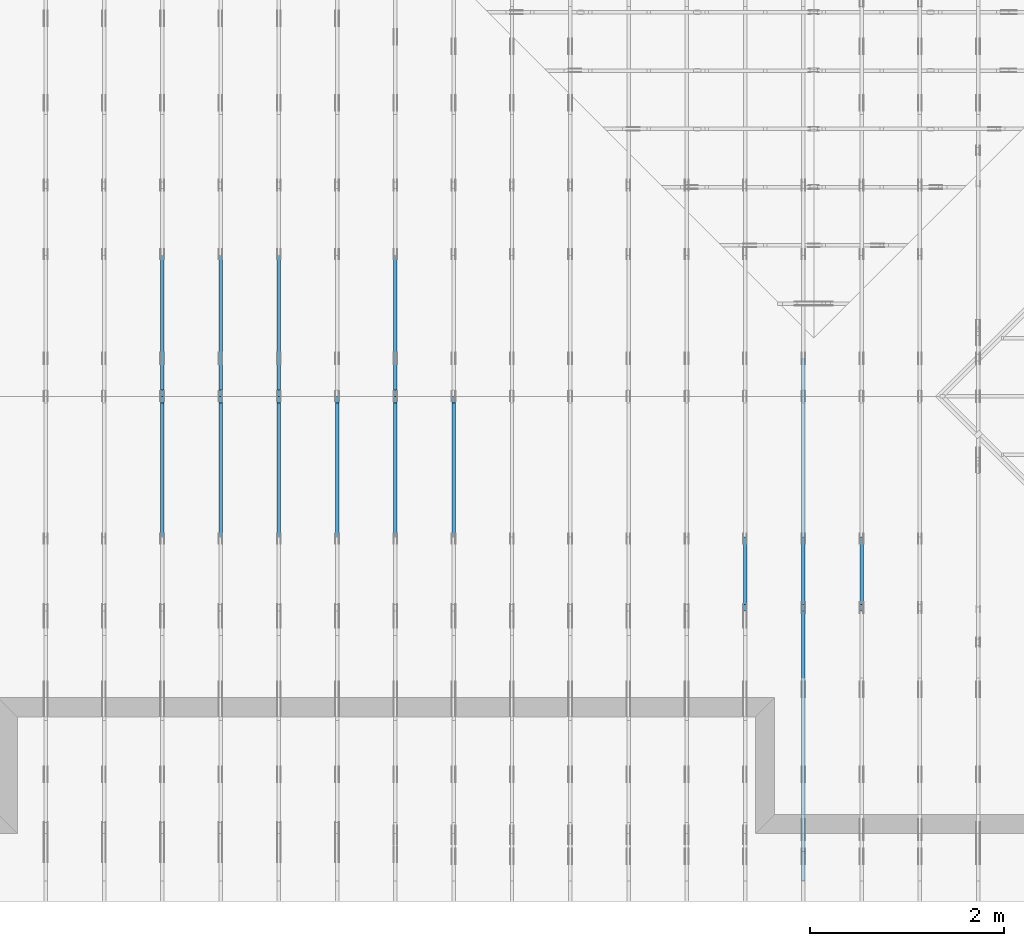
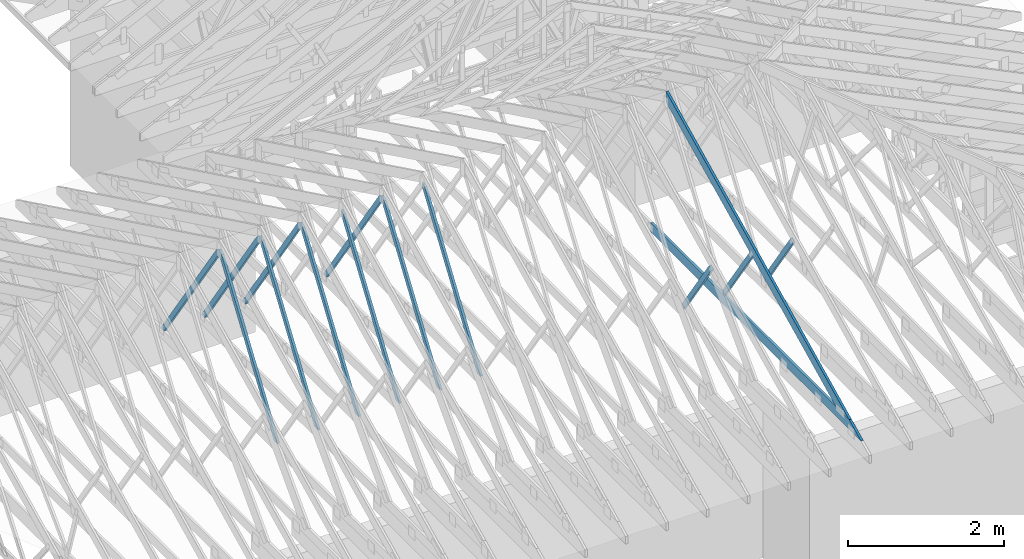
# One storey, part 15 of 159: 15 members, 9 elements without a shape of their own.
"""IFC2X3 building model written with IfcOpenShell, lengths in millimetres."""

from ifc_helpers import new_model, si_unit, frame, origin, origin_with_axes, origin_2d, place, context, project, spatial, faceted_brep, element, aggregate, save


model = new_model("IFC2X3")

# Units and contexts
model_context = context("Model", 3, precision=1e-05, world=origin())
plan_context = context("Plan", 2, precision=1e-05, world=origin_2d())
ifc_project = project(units=[si_unit("LENGTHUNIT", "METRE", prefix="MILLI"), si_unit("AREAUNIT", "SQUARE_METRE"), si_unit("VOLUMEUNIT", "CUBIC_METRE"), si_unit("SOLIDANGLEUNIT", "STERADIAN"), si_unit("PLANEANGLEUNIT", "RADIAN"), si_unit("MASSUNIT", "GRAM"), si_unit("TIMEUNIT", "SECOND"), si_unit("THERMODYNAMICTEMPERATUREUNIT", "DEGREE_CELSIUS"), si_unit("LUMINOUSINTENSITYUNIT", "LUMEN")], contexts=[model_context, plan_context])

# Site, building, storey
site_placement = place(None, origin_with_axes())
site = spatial("IfcSite", under=ifc_project, at=site_placement, CompositionType="ELEMENT")
building_placement = place(site_placement, origin_with_axes())
building = spatial("IfcBuilding", under=site, at=building_placement, Name="Plan 1", CompositionType="ELEMENT")
storey_placement = place(building_placement, origin_with_axes())
storey = spatial("IfcBuildingStorey", under=building, at=storey_placement, Name="Etasje 1", CompositionType="ELEMENT", Elevation=0.0)

# Assembly, member
assembly_1_placement = place(storey_placement, frame((15075.02226140475, -699.9989301294845, 1.1021457184401395e-15), z_axis=(-1.0, 1.836909530733566e-16, 6.123031769111886e-17), x_axis=(-1.836909530733566e-16, -1.0, 0.0)))
assembly_1 = element("IfcElementAssembly", 1, at=assembly_1_placement, inside=storey, Name="T7 (103)", AssemblyPlace="FACTORY", PredefinedType="TRUSS")
member_1_placement = place(assembly_1_placement, frame((-3053.2314180439453, 1456.2901995043017, -36.00000000000001), z_axis=(0.0, 0.0, 1.0), x_axis=(-0.5642475050080044, -0.8256056886263821, 0.0)))
member_1 = element("IfcMember", 2, at=member_1_placement, Name="T7-D42", context=model_context, shape_type="Brep", body=[
    faceted_brep([(1264.6473178393353, 73.00019836058664, 36.0), (2.90698949356738e-06, 73.00019836058664, 36.0), (10.714657584819633, 4.511090492087533e-05, 36.0), (1236.186095030735, 4.511090492087533e-05, 36.0), (2.90698949356738e-06, 73.00019836058664, 3.5599178043175084e-22), (1264.6473178393353, 73.00019836058664, 1.5486951407704775e-13), (1236.186095030735, 4.511090492087533e-05, 1.5138413464815112e-13), (10.714657584819633, 4.511090492087533e-05, 1.3121237757401251e-15), (10.714685884898016, 0.00010020237868935133, 1.010048471493429e-31), (10.714685884898017, 0.00010020237868957338, 36.0), (3.375077994860476e-14, 73.00010020237825, 36.0), (3.197442310920451e-14, 73.00010020237825, -2.1820420316813824e-30), (1236.1860298820347, 0.00010020237954454694, 5.902699555591949e-29), (1236.1860298820347, 0.00010020237954675123, 36.0), (10.714685884898017, 0.00010020237868342204, 36.0), (10.714685884898017, 0.00010020237868121774, 5.116180235117775e-31), (1264.6473849240515, 73.00010020238051, 2.686871379716991e-29), (1264.6473849240515, 73.00010020238051, 36.0), (1236.1860298820352, 0.00010020238050856278, 36.0), (1236.1860298820352, 0.00010020238050856278, 2.662727280413415e-29), (0.0, 73.00010020237823, 0.0), (0.0, 73.00010020237823, 36.0), (1264.647384924051, 73.0001002023804, 36.0), (1264.647384924051, 73.00010020238041, -7.099748146989106e-30)], [[[0, 1, 2, 3]], [[4, 5, 6, 7]], [[8, 9, 10, 11]], [[12, 13, 14, 15]], [[16, 17, 18, 19]], [[20, 21, 22, 23]]]),
])
aggregate(assembly_1, [member_1])

# Assembly, members
assembly_2_placement = place(storey_placement, frame((14475.022261404752, -699.9989301294836, 1.1021457184401395e-15), z_axis=(-1.0, 1.836909530733566e-16, 6.123031769111886e-17), x_axis=(-1.836909530733566e-16, -1.0, 0.0)))
assembly_2 = element("IfcElementAssembly", 3, at=assembly_2_placement, inside=storey, Name="T10 (102)", AssemblyPlace="FACTORY", PredefinedType="TRUSS")
member_2_placement = place(assembly_2_placement, frame((-5264.878447895178, 2523.1876964355156, -36.0), z_axis=(0.0, 0.0, 1.0), x_axis=(0.8987940462991668, -0.4383711467890778, 0.0)))
member_2 = element("IfcMember", 4, at=member_2_placement, Name="T10-O3", context=model_context, shape_type="Brep", body=[
    faceted_brep([(5212.95535395332, 148.00000154094027, 36.0), (0.0, 148.00000154094027, 36.0), (72.18440200989608, 5.7974317996922764e-05, 36.0), (4909.510382240189, 5.7974317996922764e-05, 36.0), (0.0, 148.00000154094027, 0.0), (5212.95535395332, 148.00000154094027, 6.383818248643616e-13), (4909.510382240189, 5.7974317996922764e-05, 6.012217608248263e-13), (72.18440200989608, 5.7974317996922764e-05, 8.839747734818752e-15), (72.18447769922204, 9.2140264804641e-06, -7.888609052210118e-31), (72.18447769922206, 9.2140264804641e-06, 36.0), (5.4591825588090614e-05, 148.00000921330525, 36.0), (5.4591825588090614e-05, 148.00000921330525, -7.888609052210118e-31), (4909.510401129447, 9.21290418597988e-06, 1.6550270895783706e-28), (4909.510401129447, 9.212904188184172e-06, 36.0), (72.18447769922204, 9.21402643937418e-06, 36.0), (72.18447769922204, 9.214026437169889e-06, 2.433384460947949e-30), (5212.955369681814, 148.00000921223887, 1.0605704288840677e-29), (5212.955369681814, 148.00000921223887, 36.0), (4909.510401129447, 9.212906661559828e-06, 36.0), (4909.510401129447, 9.212906661559828e-06, -1.359749288005947e-29), (5.459182557387976e-05, 148.00000921330525, 0.0), (5.459182557387976e-05, 148.00000921330525, 36.0), (5212.955369681813, 148.00000921223887, 36.0), (5212.955369681813, 148.00000921223887, 7.888609052210118e-30)], [[[0, 1, 2, 3]], [[4, 5, 6, 7]], [[8, 9, 10, 11]], [[12, 13, 14, 15]], [[16, 17, 18, 19]], [[20, 21, 22, 23]]]),
])
member_3_placement = place(assembly_2_placement, frame((-211.18128967285153, 370.99999999999994, -36.0), z_axis=(0.0, 0.0, 1.0), x_axis=(-1.0, 1.2246063538223773e-16, 0.0)))
member_3 = element("IfcMember", 5, at=member_3_placement, Name="T10-U32", context=model_context, shape_type="Brep", body=[
    faceted_brep([(5379.999862670898, 148.00000000000063, 36.0), (0.0, 148.00000000000063, 36.0), (303.4449920654297, 0.0, 36.0), (5379.999862670898, 0.0, 36.0), (0.0, 148.00000000000063, 0.0), (5379.999862670898, 148.00000000000063, 6.588382015390299e-13), (5379.999862670898, 0.0, 6.588382015390299e-13), (303.4449920654297, 0.0, 3.7160066531890605e-14), (303.44497456401575, -1.8474111129762605e-13, 1.4199496293978212e-29), (303.44497456401575, -1.8474111129762605e-13, 36.0), (6.010755903673726e-06, 148.0, 36.0), (6.010755903673726e-06, 148.0, -1.5777218104420236e-30), (5380.000006010756, -1.0494167752128893e-12, 1.2690585325561372e-28), (5380.000006010756, -1.047212483776009e-12, 36.0), (303.44497456401587, -1.146952517202135e-13, 36.0), (303.44497456401587, -1.1689954315709379e-13, 7.157796165455513e-30), (5380.000006010756, 148.000000000001, 0.0), (5380.000006010756, 148.000000000001, 36.0), (5380.000006010756, 1.0231815394945443e-12, 36.0), (5380.000006010756, 1.0231815394945443e-12, 0.0), (6.010755896568298e-06, 147.99999999999997, 0.0), (6.010755896568298e-06, 147.99999999999997, 36.0), (5380.000006010756, 148.00000000000082, 36.0), (5380.000006010756, 148.00000000000082, -9.466330862652142e-30)], [[[0, 1, 2, 3]], [[4, 5, 6, 7]], [[8, 9, 10, 11]], [[12, 13, 14, 15]], [[16, 17, 18, 19]], [[20, 21, 22, 23]]]),
])
member_4_placement = place(assembly_2_placement, frame((-3053.2314180439453, 1456.2901995043017, -36.00000000000001), z_axis=(0.0, 0.0, 1.0), x_axis=(-0.5642475050080044, -0.8256056886263821, 0.0)))
member_4 = element("IfcMember", 6, at=member_4_placement, Name="T10-D42", context=model_context, shape_type="Brep", body=[
    faceted_brep([(1264.6473178393353, 73.00019836058664, 36.0), (2.90698949356738e-06, 73.00019836058664, 36.0), (10.714657584819633, 4.511090492087533e-05, 36.0), (1236.186095030735, 4.511090492087533e-05, 36.0), (2.90698949356738e-06, 73.00019836058664, 3.5599178043175084e-22), (1264.6473178393353, 73.00019836058664, 1.5486951407704775e-13), (1236.186095030735, 4.511090492087533e-05, 1.5138413464815112e-13), (10.714657584819633, 4.511090492087533e-05, 1.3121237757401251e-15), (10.714685884898016, 0.00010020237868935133, 1.010048471493429e-31), (10.714685884898017, 0.00010020237868957338, 36.0), (3.375077994860476e-14, 73.00010020237825, 36.0), (3.197442310920451e-14, 73.00010020237825, -2.1820420316813824e-30), (1236.1860298820347, 0.00010020237954454694, 5.902699555591949e-29), (1236.1860298820347, 0.00010020237954675123, 36.0), (10.714685884898017, 0.00010020237868342204, 36.0), (10.714685884898017, 0.00010020237868121774, 5.116180235117775e-31), (1264.6473849240515, 73.00010020238051, 2.686871379716991e-29), (1264.6473849240515, 73.00010020238051, 36.0), (1236.1860298820352, 0.00010020238050856278, 36.0), (1236.1860298820352, 0.00010020238050856278, 2.662727280413415e-29), (0.0, 73.00010020237823, 0.0), (0.0, 73.00010020237823, 36.0), (1264.647384924051, 73.0001002023804, 36.0), (1264.647384924051, 73.00010020238041, -7.099748146989106e-30)], [[[0, 1, 2, 3]], [[4, 5, 6, 7]], [[8, 9, 10, 11]], [[12, 13, 14, 15]], [[16, 17, 18, 19]], [[20, 21, 22, 23]]]),
])
aggregate(assembly_2, [member_2, member_3, member_4])

# Assembly, member
assembly_3_placement = place(storey_placement, frame((13875.022261404752, -699.9989301294836, 1.1021457184401395e-15), z_axis=(-1.0, 1.836909530733566e-16, 6.123031769111886e-17), x_axis=(-1.836909530733566e-16, -1.0, 0.0)))
assembly_3 = element("IfcElementAssembly", 7, at=assembly_3_placement, inside=storey, Name="T6 (101)", AssemblyPlace="FACTORY", PredefinedType="TRUSS")
member_5_placement = place(assembly_3_placement, frame((-3053.2314180439453, 1456.2901995043017, -36.00000000000001), z_axis=(0.0, 0.0, 1.0), x_axis=(-0.5642475050080044, -0.8256056886263821, 0.0)))
member_5 = element("IfcMember", 8, at=member_5_placement, Name="T6-D42", context=model_context, shape_type="Brep", body=[
    faceted_brep([(1264.6473178393353, 73.00019836058664, 36.0), (2.90698949356738e-06, 73.00019836058664, 36.0), (10.714657584819633, 4.511090492087533e-05, 36.0), (1236.186095030735, 4.511090492087533e-05, 36.0), (2.90698949356738e-06, 73.00019836058664, 3.5599178043175084e-22), (1264.6473178393353, 73.00019836058664, 1.5486951407704775e-13), (1236.186095030735, 4.511090492087533e-05, 1.5138413464815112e-13), (10.714657584819633, 4.511090492087533e-05, 1.3121237757401251e-15), (10.714685884898016, 0.00010020237868935133, 1.010048471493429e-31), (10.714685884898017, 0.00010020237868957338, 36.0), (3.375077994860476e-14, 73.00010020237825, 36.0), (3.197442310920451e-14, 73.00010020237825, -2.1820420316813824e-30), (1236.1860298820347, 0.00010020237954454694, 5.902699555591949e-29), (1236.1860298820347, 0.00010020237954675123, 36.0), (10.714685884898017, 0.00010020237868342204, 36.0), (10.714685884898017, 0.00010020237868121774, 5.116180235117775e-31), (1264.6473849240515, 73.00010020238051, 2.686871379716991e-29), (1264.6473849240515, 73.00010020238051, 36.0), (1236.1860298820352, 0.00010020238050856278, 36.0), (1236.1860298820352, 0.00010020238050856278, 2.662727280413415e-29), (0.0, 73.00010020237823, 0.0), (0.0, 73.00010020237823, 36.0), (1264.647384924051, 73.0001002023804, 36.0), (1264.647384924051, 73.00010020238041, -7.099748146989106e-30)], [[[0, 1, 2, 3]], [[4, 5, 6, 7]], [[8, 9, 10, 11]], [[12, 13, 14, 15]], [[16, 17, 18, 19]], [[20, 21, 22, 23]]]),
])
aggregate(assembly_3, [member_5])

assembly_4_placement = place(storey_placement, frame((10875.02226140475, -699.9989301294845, 1.1021457184401395e-15), z_axis=(-1.0, 1.836909530733566e-16, 6.123031769111886e-17), x_axis=(-1.836909530733566e-16, -1.0, 0.0)))
assembly_4 = element("IfcElementAssembly", 9, at=assembly_4_placement, inside=storey, Name="T4 (96)", AssemblyPlace="FACTORY", PredefinedType="TRUSS")
member_6_placement = place(assembly_4_placement, frame((-5230.134200945327, 2470.9490997577877, -36.0), z_axis=(0.0, 0.0, 1.0), x_axis=(0.5642475050069341, -0.8256056886271133, 0.0)))
member_6 = element("IfcMember", 10, at=member_6_placement, Name="T4-D10", context=model_context, shape_type="Brep", body=[
    faceted_brep([(2593.4163311647476, 73.00019205185345, 36.0), (64.12142578857947, 73.00019205185345, 36.0), (0.0, 36.500098826461, 36.0), (53.40677111084369, 6.283484799496364e-05, 36.0), (2543.5254730981324, 6.283484799496364e-05, 36.0), (64.12142578857947, 73.00019205185345, 7.852350543684446e-15), (2593.4163311647476, 73.00019205185345, 3.1759141172510683e-13), (2543.5254730981324, 6.283484799496364e-05, 3.114817455465041e-13), (53.40677111084369, 6.283484799496364e-05, 6.540227123947657e-15), (0.0, 36.500098826461, 0.0), (8.990210517012542e-05, 36.5000938930789, 3.944304526105059e-31), (8.990210517190178e-05, 36.50009389307889, 36.0), (64.12149423251047, 73.00009389364551, 36.0), (64.12149423251047, 73.00009389364551, 7.888609052210118e-31), (53.40680834923477, 9.3893645480847e-05, 1.1832913578315177e-30), (53.40680834923477, 9.389364548439971e-05, 36.0), (8.990210517723085e-05, 36.50009389307888, 36.0), (8.990210517723085e-05, 36.500093893078876, 3.944304526105059e-31), (2543.5255372683005, 9.389364500212836e-05, 1.1393273801051142e-28), (2543.5255372683005, 9.389364500433265e-05, 36.0), (53.40680834923478, 9.389364546174493e-05, 36.0), (53.40680834923478, 9.389364545954064e-05, 2.3922645400816085e-30), (2593.4162640800278, 73.00009389364232, -5.048709793414476e-29), (2593.4162640800278, 73.00009389364232, 36.0), (2543.5255372683, 9.38936470902263e-05, 36.0), (2543.5255372683, 9.38936470902263e-05, -5.048709793414476e-29), (64.12149423251049, 73.00009389364551, 0.0), (64.12149423251049, 73.00009389364551, 36.0), (2593.416264080028, 73.00009389364254, 36.0), (2593.416264080028, 73.00009389364254, 4.1809627976713626e-29)], [[[0, 1, 2, 3, 4]], [[5, 6, 7, 8, 9]], [[10, 11, 12, 13]], [[14, 15, 16, 17]], [[18, 19, 20, 21]], [[22, 23, 24, 25]], [[26, 27, 28, 29]]]),
])
aggregate(assembly_4, [member_6])

# Assembly, members
assembly_5_placement = place(storey_placement, frame((10275.02226140475, -699.9989301294845, 1.1021457184401395e-15), z_axis=(-1.0, 1.836909530733566e-16, 6.123031769111886e-17), x_axis=(-1.836909530733566e-16, -1.0, 0.0)))
assembly_5 = element("IfcElementAssembly", 11, at=assembly_5_placement, inside=storey, Name="T3 (95)", AssemblyPlace="FACTORY", PredefinedType="TRUSS")
member_7_placement = place(assembly_5_placement, frame((-5230.134100229103, 2512.139209339855, -36.0), z_axis=(0.0, 0.0, 1.0), x_axis=(-0.5642474867869504, -0.8256057010792806, 0.0)))
member_7 = element("IfcMember", 12, at=member_7_placement, Name="T3-D10", context=model_context, shape_type="Brep", body=[
    faceted_brep([(2543.5253361479054, 73.00022054347846, 36.0), (53.4067719163495, 73.00022054347846, 36.0), (0.0, 36.49997628523852, 36.0), (64.12142498307549, 0.0, 36.0), (2593.416054847772, 0.0, 36.0), (53.4067719163495, 73.00022054347846, 6.540227222590409e-15), (2543.5253361479054, 73.00022054347846, 3.1148172877549227e-13), (2593.416054847772, 0.0, 3.1759137788715447e-13), (64.12142498307549, 0.0, 7.852350445041915e-15), (0.0, 36.49997628523852, 0.0), (3.725328997106203e-05, 36.50005825425252, 7.888609052210118e-31), (3.725328997106203e-05, 36.50005825425252, 36.0), (53.40675633295018, 73.00005825368592, 36.0), (53.40675633295018, 73.00005825368592, 7.888609052210118e-31), (64.12143968753047, 5.825368587863977e-05, 1.3550091400468847e-30), (64.12143968753047, 5.8253685882192485e-05, 36.0), (3.72532899763911e-05, 36.50005825425251, 36.0), (3.7253289974614745e-05, 36.50005825425251, -5.564099164698829e-32), (2593.416171510612, 5.825367866761415e-05, 5.258297765442924e-29), (2593.416171510612, 5.825367866981844e-05, 36.0), (64.12143968753048, 5.8253685873822e-05, 36.0), (64.12143968753048, 5.8253685871617706e-05, 1.300098256642219e-30), (2543.5254470623668, 73.00005825367862, 2.524354896707238e-29), (2543.5254470623668, 73.00005825367862, 36.0), (2593.4161715106125, 5.8253679526387714e-05, 36.0), (2593.4161715106125, 5.8253679526387714e-05, 2.524354896707238e-29), (53.40675633295018, 73.00005825368589, 0.0), (53.40675633295018, 73.00005825368589, 36.0), (2543.5254470623668, 73.00005825367855, 36.0), (2543.5254470623668, 73.00005825367855, -3.944304526105059e-30)], [[[0, 1, 2, 3, 4]], [[5, 6, 7, 8, 9]], [[10, 11, 12, 13]], [[14, 15, 16, 17]], [[18, 19, 20, 21]], [[22, 23, 24, 25]], [[26, 27, 28, 29]]]),
])
member_8_placement = place(assembly_5_placement, frame((-5230.1341493278105, 2470.9491345471442, -36.0), z_axis=(0.0, 0.0, 1.0), x_axis=(0.5642475141171904, -0.8256056824008486, 0.0)))
member_8 = element("IfcMember", 13, at=member_8_placement, Name="T3-D10", context=model_context, shape_type="Brep", body=[
    faceted_brep([(2593.4163315675128, 73.00010118893124, 36.0), (64.12142619134283, 73.00010118893124, 36.0), (0.0, 36.50003658093692, 36.0), (53.40677070807942, 0.0, 36.0), (2543.5256104511077, 0.0, 36.0), (64.12142619134283, 73.00010118893124, 7.852350593007104e-15), (2593.4163315675128, 73.00010118893124, 3.1759141177442974e-13), (2543.5256104511077, 0.0, 3.1148176236683675e-13), (53.40677070807942, 0.0, 6.540227074624888e-15), (0.0, 36.50003658093692, 0.0), (8.990210425885437e-05, 36.500031647553456, 7.332196159336271e-31), (8.990210426063072e-05, 36.500031647553456, 36.0), (64.12149588160628, 73.00003164812054, 36.0), (64.12149588160628, 73.00003164812054, 9.002912851875303e-31), (53.4068089817656, 3.1648120508265265e-05, 3.944304526105059e-31), (53.4068089817656, 3.164812051181798e-05, 36.0), (8.990210426418344e-05, 36.50003164755344, 36.0), (8.990210426418344e-05, 36.50003164755344, 0.0), (2543.5255560474043, 3.164811561416505e-05, 4.9285921758903895e-29), (2543.5255560474043, 3.164811561636934e-05, 36.0), (53.40680898176561, 3.1648120497121096e-05, 36.0), (53.40680898176561, 3.1648120494916805e-05, 1.0348642252209852e-30), (2593.4162840409117, 73.00003164811665, 2.524354896707238e-29), (2593.4162840409117, 73.00003164811665, 36.0), (2543.5255560474043, 3.1648116191718145e-05, 36.0), (2543.5255560474043, 3.1648116191718145e-05, 2.524354896707238e-29), (64.12149588160628, 73.00003164812053, 0.0), (64.12149588160628, 73.00003164812053, 36.0), (2593.4162840409117, 73.00003164811756, 36.0), (2593.4162840409117, 73.00003164811756, 4.1809627976713626e-29)], [[[0, 1, 2, 3, 4]], [[5, 6, 7, 8, 9]], [[10, 11, 12, 13]], [[14, 15, 16, 17]], [[18, 19, 20, 21]], [[22, 23, 24, 25]], [[26, 27, 28, 29]]]),
])
aggregate(assembly_5, [member_7, member_8])

# Assembly, member
assembly_6_placement = place(storey_placement, frame((9675.022261404752, 9699.99999999999, 1.1021457184401395e-15), z_axis=(-1.0, 1.836909530733566e-16, 6.123031769111886e-17), x_axis=(-1.836909530733566e-16, -1.0, 0.0)))
assembly_6 = element("IfcElementAssembly", 14, at=assembly_6_placement, inside=storey, Name="T2 (94)", AssemblyPlace="FACTORY", PredefinedType="TRUSS")
member_9_placement = place(assembly_6_placement, frame((5169.864836410244, 2470.9491092698727, -36.0), z_axis=(0.0, 0.0, 1.0), x_axis=(0.5642475050070653, -0.8256056886270235, 0.0)))
member_9 = element("IfcMember", 15, at=member_9_placement, Name="T2-D10", context=model_context, shape_type="Brep", body=[
    faceted_brep([(2593.4163311647535, 73.00017519343237, 36.0), (64.12142578858538, 73.00017519343237, 36.0), (0.0, 36.50008196845101, 36.0), (53.406771110838235, 4.597682982421247e-05, 36.0), (2543.525610853865, 4.597682982421247e-05, 36.0), (64.12142578858538, 73.00017519343237, 7.85235054368517e-15), (2593.4163311647535, 73.00017519343237, 3.175914117251076e-13), (2543.525610853865, 4.597682982421247e-05, 3.1148176241615866e-13), (53.406771110838235, 4.597682982421247e-05, 6.540227123946988e-15), (0.0, 36.50008196845101, 0.0), (3.725174792457153e-05, 36.50000000048476, 5.564110112461459e-32), (3.725174792634789e-05, 36.50000000048476, 36.0), (64.12144158370505, 73.0000000000009, 36.0), (64.12144158370505, 73.0000000000009, -5.058610251535388e-31), (53.40675570041139, -3.552713678800501e-15, 3.944304526105059e-31), (53.40675570041139, 0.0, 36.0), (3.725174792634789e-05, 36.50000000048476, 36.0), (3.725174792634789e-05, 36.50000000048476, 0.0), (2543.5254846197568, 1.0633235970486703e-11, -9.418992127807544e-29), (2543.5254846197568, 1.0635440261923583e-11, 36.0), (53.406755700411395, 3.450395691825015e-14, 36.0), (53.406755700411395, 3.229966548136987e-14, -1.9777187787411422e-30), (2593.4162114315045, 73.00000000000773, 2.524354896707238e-29), (2593.4162114315045, 73.00000000000773, 36.0), (2543.525484619757, 8.86757334228605e-12, 36.0), (2543.525484619757, 8.86757334228605e-12, 0.0), (64.12144158370506, 73.00000000000092, 0.0), (64.12144158370506, 73.00000000000092, 36.0), (2593.416211431504, 73.00000000000863, 36.0), (2593.416211431504, 73.00000000000863, 2.68212707775144e-29)], [[[0, 1, 2, 3, 4]], [[5, 6, 7, 8, 9]], [[10, 11, 12, 13]], [[14, 15, 16, 17]], [[18, 19, 20, 21]], [[22, 23, 24, 25]], [[26, 27, 28, 29]]]),
])
aggregate(assembly_6, [member_9])

# Assembly, members
assembly_7_placement = place(storey_placement, frame((9075.022261404752, 9699.99999999999, 1.1021457184401395e-15), z_axis=(-1.0, 1.836909530733566e-16, 6.123031769111886e-17), x_axis=(-1.836909530733566e-16, -1.0, 0.0)))
assembly_7 = element("IfcElementAssembly", 16, at=assembly_7_placement, inside=storey, Name="T2 (93)", AssemblyPlace="FACTORY", PredefinedType="TRUSS")
member_10_placement = place(assembly_7_placement, frame((5169.864827117615, 2512.139275987297, -36.0), z_axis=(0.0, 0.0, 1.0), x_axis=(-0.564247505007381, -0.8256056886268078, 0.0)))
member_10 = element("IfcMember", 17, at=member_10_placement, Name="T2-D10", context=model_context, shape_type="Brep", body=[
    faceted_brep([(2543.525473098112, 73.00019205182707, 36.0), (53.406771110823684, 73.00019205182707, 36.0), (0.0, 36.5000932239891, 36.0), (64.12142578859857, 0.00011835385657832376, 36.0), (2593.4163311647667, 0.00011835385657832376, 36.0), (53.406771110823684, 73.00019205182707, 6.540227123945206e-15), (2543.525473098112, 73.00019205182707, 3.114817455465016e-13), (2593.4163311647667, 0.00011835385657832376, 3.175914117251092e-13), (64.12142578859857, 0.00011835385657832376, 7.852350543686785e-15), (0.0, 36.5000932239891, 0.0), (8.990056994662154e-05, 36.50009815631665, 3.944304526105059e-31), (8.990056994662154e-05, 36.50009815631665, 36.0), (53.40680834923387, 73.00009815680099, 36.0), (53.40680834923387, 73.00009815680099, 7.888609052210118e-31), (64.12149423256596, 9.815680185809583e-05, 6.171430365172586e-31), (64.12149423256596, 9.815680186164855e-05, 36.0), (8.990056995195062e-05, 36.50009815631667, 36.0), (8.990056995017426e-05, 36.50009815631666, -3.3878954237129854e-31), (2593.4162640810096, 9.815680364966906e-05, 2.3313020864942917e-30), (2593.4162640810096, 9.815680365187335e-05, 36.0), (64.12149423256596, 9.815680187001689e-05, 36.0), (64.12149423256596, 9.81568018678126e-05, 5.76409767496333e-32), (2543.5255372692222, 73.00009815680278, 0.0), (2543.5255372692222, 73.00009815680278, 36.0), (2593.4162640810096, 9.815680414249073e-05, 36.0), (2593.4162640810096, 9.815680414249073e-05, 0.0), (53.40680834923387, 73.00009815680097, 7.888609052210118e-31), (53.40680834923387, 73.00009815680097, 36.0), (2543.525537269222, 73.00009815680359, 36.0), (2543.525537269222, 73.00009815680359, 4.9698237028923744e-29)], [[[0, 1, 2, 3, 4]], [[5, 6, 7, 8, 9]], [[10, 11, 12, 13]], [[14, 15, 16, 17]], [[18, 19, 20, 21]], [[22, 23, 24, 25]], [[26, 27, 28, 29]]]),
])
member_11_placement = place(assembly_7_placement, frame((5169.864836410244, 2470.9491092698727, -36.0), z_axis=(0.0, 0.0, 1.0), x_axis=(0.5642475050070653, -0.8256056886270235, 0.0)))
member_11 = element("IfcMember", 18, at=member_11_placement, Name="T2-D10", context=model_context, shape_type="Brep", body=[
    faceted_brep([(2593.4163311647535, 73.00017519343237, 36.0), (64.12142578858538, 73.00017519343237, 36.0), (0.0, 36.50008196845101, 36.0), (53.406771110838235, 4.597682982421247e-05, 36.0), (2543.525610853865, 4.597682982421247e-05, 36.0), (64.12142578858538, 73.00017519343237, 7.85235054368517e-15), (2593.4163311647535, 73.00017519343237, 3.175914117251076e-13), (2543.525610853865, 4.597682982421247e-05, 3.1148176241615866e-13), (53.406771110838235, 4.597682982421247e-05, 6.540227123946988e-15), (0.0, 36.50008196845101, 0.0), (3.725174792457153e-05, 36.50000000048476, 5.564110112461459e-32), (3.725174792634789e-05, 36.50000000048476, 36.0), (64.12144158370505, 73.0000000000009, 36.0), (64.12144158370505, 73.0000000000009, -5.058610251535388e-31), (53.40675570041139, -3.552713678800501e-15, 3.944304526105059e-31), (53.40675570041139, 0.0, 36.0), (3.725174792634789e-05, 36.50000000048476, 36.0), (3.725174792634789e-05, 36.50000000048476, 0.0), (2543.5254846197568, 1.0633235970486703e-11, -9.418992127807544e-29), (2543.5254846197568, 1.0635440261923583e-11, 36.0), (53.406755700411395, 3.450395691825015e-14, 36.0), (53.406755700411395, 3.229966548136987e-14, -1.9777187787411422e-30), (2593.4162114315045, 73.00000000000773, 2.524354896707238e-29), (2593.4162114315045, 73.00000000000773, 36.0), (2543.525484619757, 8.86757334228605e-12, 36.0), (2543.525484619757, 8.86757334228605e-12, 0.0), (64.12144158370506, 73.00000000000092, 0.0), (64.12144158370506, 73.00000000000092, 36.0), (2593.416211431504, 73.00000000000863, 36.0), (2593.416211431504, 73.00000000000863, 2.68212707775144e-29)], [[[0, 1, 2, 3, 4]], [[5, 6, 7, 8, 9]], [[10, 11, 12, 13]], [[14, 15, 16, 17]], [[18, 19, 20, 21]], [[22, 23, 24, 25]], [[26, 27, 28, 29]]]),
])
aggregate(assembly_7, [member_10, member_11])

assembly_8_placement = place(storey_placement, frame((8475.022261404752, 9699.99999999999, 1.1021457184401395e-15), z_axis=(-1.0, 1.836909530733566e-16, 6.123031769111886e-17), x_axis=(-1.836909530733566e-16, -1.0, 0.0)))
assembly_8 = element("IfcElementAssembly", 19, at=assembly_8_placement, inside=storey, Name="T2 (92)", AssemblyPlace="FACTORY", PredefinedType="TRUSS")
member_12_placement = place(assembly_8_placement, frame((5169.864827117615, 2512.139275987297, -36.0), z_axis=(0.0, 0.0, 1.0), x_axis=(-0.564247505007381, -0.8256056886268078, 0.0)))
member_12 = element("IfcMember", 20, at=member_12_placement, Name="T2-D10", context=model_context, shape_type="Brep", body=[
    faceted_brep([(2543.525473098112, 73.00019205182707, 36.0), (53.406771110823684, 73.00019205182707, 36.0), (0.0, 36.5000932239891, 36.0), (64.12142578859857, 0.00011835385657832376, 36.0), (2593.4163311647667, 0.00011835385657832376, 36.0), (53.406771110823684, 73.00019205182707, 6.540227123945206e-15), (2543.525473098112, 73.00019205182707, 3.114817455465016e-13), (2593.4163311647667, 0.00011835385657832376, 3.175914117251092e-13), (64.12142578859857, 0.00011835385657832376, 7.852350543686785e-15), (0.0, 36.5000932239891, 0.0), (8.990056994662154e-05, 36.50009815631665, 3.944304526105059e-31), (8.990056994662154e-05, 36.50009815631665, 36.0), (53.40680834923387, 73.00009815680099, 36.0), (53.40680834923387, 73.00009815680099, 7.888609052210118e-31), (64.12149423256596, 9.815680185809583e-05, 6.171430365172586e-31), (64.12149423256596, 9.815680186164855e-05, 36.0), (8.990056995195062e-05, 36.50009815631667, 36.0), (8.990056995017426e-05, 36.50009815631666, -3.3878954237129854e-31), (2593.4162640810096, 9.815680364966906e-05, 2.3313020864942917e-30), (2593.4162640810096, 9.815680365187335e-05, 36.0), (64.12149423256596, 9.815680187001689e-05, 36.0), (64.12149423256596, 9.81568018678126e-05, 5.76409767496333e-32), (2543.5255372692222, 73.00009815680278, 0.0), (2543.5255372692222, 73.00009815680278, 36.0), (2593.4162640810096, 9.815680414249073e-05, 36.0), (2593.4162640810096, 9.815680414249073e-05, 0.0), (53.40680834923387, 73.00009815680097, 7.888609052210118e-31), (53.40680834923387, 73.00009815680097, 36.0), (2543.525537269222, 73.00009815680359, 36.0), (2543.525537269222, 73.00009815680359, 4.9698237028923744e-29)], [[[0, 1, 2, 3, 4]], [[5, 6, 7, 8, 9]], [[10, 11, 12, 13]], [[14, 15, 16, 17]], [[18, 19, 20, 21]], [[22, 23, 24, 25]], [[26, 27, 28, 29]]]),
])
member_13_placement = place(assembly_8_placement, frame((5169.864836410244, 2470.9491092698727, -36.0), z_axis=(0.0, 0.0, 1.0), x_axis=(0.5642475050070653, -0.8256056886270235, 0.0)))
member_13 = element("IfcMember", 21, at=member_13_placement, Name="T2-D10", context=model_context, shape_type="Brep", body=[
    faceted_brep([(2593.4163311647535, 73.00017519343237, 36.0), (64.12142578858538, 73.00017519343237, 36.0), (0.0, 36.50008196845101, 36.0), (53.406771110838235, 4.597682982421247e-05, 36.0), (2543.525610853865, 4.597682982421247e-05, 36.0), (64.12142578858538, 73.00017519343237, 7.85235054368517e-15), (2593.4163311647535, 73.00017519343237, 3.175914117251076e-13), (2543.525610853865, 4.597682982421247e-05, 3.1148176241615866e-13), (53.406771110838235, 4.597682982421247e-05, 6.540227123946988e-15), (0.0, 36.50008196845101, 0.0), (3.725174792457153e-05, 36.50000000048476, 5.564110112461459e-32), (3.725174792634789e-05, 36.50000000048476, 36.0), (64.12144158370505, 73.0000000000009, 36.0), (64.12144158370505, 73.0000000000009, -5.058610251535388e-31), (53.40675570041139, -3.552713678800501e-15, 3.944304526105059e-31), (53.40675570041139, 0.0, 36.0), (3.725174792634789e-05, 36.50000000048476, 36.0), (3.725174792634789e-05, 36.50000000048476, 0.0), (2543.5254846197568, 1.0633235970486703e-11, -9.418992127807544e-29), (2543.5254846197568, 1.0635440261923583e-11, 36.0), (53.406755700411395, 3.450395691825015e-14, 36.0), (53.406755700411395, 3.229966548136987e-14, -1.9777187787411422e-30), (2593.4162114315045, 73.00000000000773, 2.524354896707238e-29), (2593.4162114315045, 73.00000000000773, 36.0), (2543.525484619757, 8.86757334228605e-12, 36.0), (2543.525484619757, 8.86757334228605e-12, 0.0), (64.12144158370506, 73.00000000000092, 0.0), (64.12144158370506, 73.00000000000092, 36.0), (2593.416211431504, 73.00000000000863, 36.0), (2593.416211431504, 73.00000000000863, 2.68212707775144e-29)], [[[0, 1, 2, 3, 4]], [[5, 6, 7, 8, 9]], [[10, 11, 12, 13]], [[14, 15, 16, 17]], [[18, 19, 20, 21]], [[22, 23, 24, 25]], [[26, 27, 28, 29]]]),
])
aggregate(assembly_8, [member_12, member_13])

assembly_9_placement = place(storey_placement, frame((7875.0222614047525, 9699.99999999999, 1.1021457184401395e-15), z_axis=(-1.0, 1.836909530733566e-16, 6.123031769111886e-17), x_axis=(-1.836909530733566e-16, -1.0, 0.0)))
assembly_9 = element("IfcElementAssembly", 22, at=assembly_9_placement, inside=storey, Name="T2 (91)", AssemblyPlace="FACTORY", PredefinedType="TRUSS")
member_14_placement = place(assembly_9_placement, frame((5169.864827117615, 2512.139275987297, -36.0), z_axis=(0.0, 0.0, 1.0), x_axis=(-0.564247505007381, -0.8256056886268078, 0.0)))
member_14 = element("IfcMember", 23, at=member_14_placement, Name="T2-D10", context=model_context, shape_type="Brep", body=[
    faceted_brep([(2543.525473098112, 73.00019205182707, 36.0), (53.406771110823684, 73.00019205182707, 36.0), (0.0, 36.5000932239891, 36.0), (64.12142578859857, 0.00011835385657832376, 36.0), (2593.4163311647667, 0.00011835385657832376, 36.0), (53.406771110823684, 73.00019205182707, 6.540227123945206e-15), (2543.525473098112, 73.00019205182707, 3.114817455465016e-13), (2593.4163311647667, 0.00011835385657832376, 3.175914117251092e-13), (64.12142578859857, 0.00011835385657832376, 7.852350543686785e-15), (0.0, 36.5000932239891, 0.0), (8.990056994662154e-05, 36.50009815631665, 3.944304526105059e-31), (8.990056994662154e-05, 36.50009815631665, 36.0), (53.40680834923387, 73.00009815680099, 36.0), (53.40680834923387, 73.00009815680099, 7.888609052210118e-31), (64.12149423256596, 9.815680185809583e-05, 6.171430365172586e-31), (64.12149423256596, 9.815680186164855e-05, 36.0), (8.990056995195062e-05, 36.50009815631667, 36.0), (8.990056995017426e-05, 36.50009815631666, -3.3878954237129854e-31), (2593.4162640810096, 9.815680364966906e-05, 2.3313020864942917e-30), (2593.4162640810096, 9.815680365187335e-05, 36.0), (64.12149423256596, 9.815680187001689e-05, 36.0), (64.12149423256596, 9.81568018678126e-05, 5.76409767496333e-32), (2543.5255372692222, 73.00009815680278, 0.0), (2543.5255372692222, 73.00009815680278, 36.0), (2593.4162640810096, 9.815680414249073e-05, 36.0), (2593.4162640810096, 9.815680414249073e-05, 0.0), (53.40680834923387, 73.00009815680097, 7.888609052210118e-31), (53.40680834923387, 73.00009815680097, 36.0), (2543.525537269222, 73.00009815680359, 36.0), (2543.525537269222, 73.00009815680359, 4.9698237028923744e-29)], [[[0, 1, 2, 3, 4]], [[5, 6, 7, 8, 9]], [[10, 11, 12, 13]], [[14, 15, 16, 17]], [[18, 19, 20, 21]], [[22, 23, 24, 25]], [[26, 27, 28, 29]]]),
])
member_15_placement = place(assembly_9_placement, frame((5169.864836410244, 2470.9491092698727, -36.0), z_axis=(0.0, 0.0, 1.0), x_axis=(0.5642475050070653, -0.8256056886270235, 0.0)))
member_15 = element("IfcMember", 24, at=member_15_placement, Name="T2-D10", context=model_context, shape_type="Brep", body=[
    faceted_brep([(2593.4163311647535, 73.00017519343237, 36.0), (64.12142578858538, 73.00017519343237, 36.0), (0.0, 36.50008196845101, 36.0), (53.406771110838235, 4.597682982421247e-05, 36.0), (2543.525610853865, 4.597682982421247e-05, 36.0), (64.12142578858538, 73.00017519343237, 7.85235054368517e-15), (2593.4163311647535, 73.00017519343237, 3.175914117251076e-13), (2543.525610853865, 4.597682982421247e-05, 3.1148176241615866e-13), (53.406771110838235, 4.597682982421247e-05, 6.540227123946988e-15), (0.0, 36.50008196845101, 0.0), (3.725174792457153e-05, 36.50000000048476, 5.564110112461459e-32), (3.725174792634789e-05, 36.50000000048476, 36.0), (64.12144158370505, 73.0000000000009, 36.0), (64.12144158370505, 73.0000000000009, -5.058610251535388e-31), (53.40675570041139, -3.552713678800501e-15, 3.944304526105059e-31), (53.40675570041139, 0.0, 36.0), (3.725174792634789e-05, 36.50000000048476, 36.0), (3.725174792634789e-05, 36.50000000048476, 0.0), (2543.5254846197568, 1.0633235970486703e-11, -9.418992127807544e-29), (2543.5254846197568, 1.0635440261923583e-11, 36.0), (53.406755700411395, 3.450395691825015e-14, 36.0), (53.406755700411395, 3.229966548136987e-14, -1.9777187787411422e-30), (2593.4162114315045, 73.00000000000773, 2.524354896707238e-29), (2593.4162114315045, 73.00000000000773, 36.0), (2543.525484619757, 8.86757334228605e-12, 36.0), (2543.525484619757, 8.86757334228605e-12, 0.0), (64.12144158370506, 73.00000000000092, 0.0), (64.12144158370506, 73.00000000000092, 36.0), (2593.416211431504, 73.00000000000863, 36.0), (2593.416211431504, 73.00000000000863, 2.68212707775144e-29)], [[[0, 1, 2, 3, 4]], [[5, 6, 7, 8, 9]], [[10, 11, 12, 13]], [[14, 15, 16, 17]], [[18, 19, 20, 21]], [[22, 23, 24, 25]], [[26, 27, 28, 29]]]),
])
aggregate(assembly_9, [member_14, member_15])

save(model, "model.ifc")
